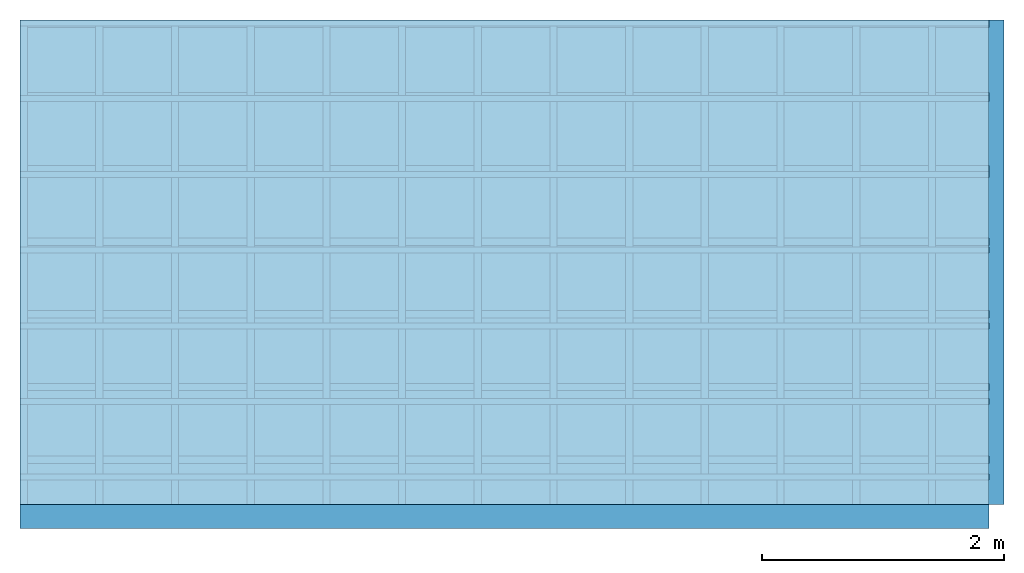
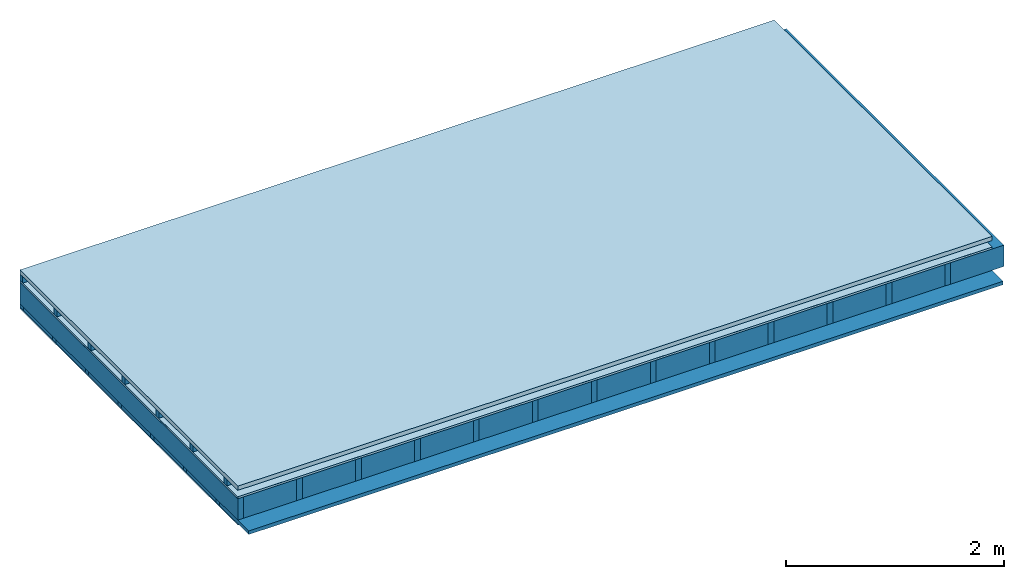
# One storey: 5 members, 4 plates, 1 element without a shape of its own.
"""IFC4 building model written with IfcOpenShell, lengths in metres."""

from ifc_helpers import new_model, si_unit, derived_unit, direction, frame, frame_2d, origin, origin_with_axes, place, context, project, spatial, rectangle, extrude, material, layer, layer_set, type_object, element, aggregate, save


model = new_model("IFC4")

# Units and contexts
plan_context = context("Plan", 3, precision=1e-05, world=origin(), true_north=direction((0.0, 1.0)))
model_context = context("Model", 3, precision=1e-05, world=origin(), true_north=direction((0.0, 1.0)))
ifc_project = project(units=[si_unit("LENGTHUNIT", "METRE"), derived_unit("SOUNDPRESSUREUNIT", [(si_unit("PRESSUREUNIT", "PASCAL", prefix="MICRO"), 0)]), si_unit("ENERGYUNIT", "JOULE", prefix="MEGA"), si_unit("MASSUNIT", "GRAM", prefix="KILO"), derived_unit("THERMALTRANSMITTANCEUNIT", [(si_unit("POWERUNIT", "WATT"), 1), (si_unit("AREAUNIT", "SQUARE_METRE"), -1), (si_unit("THERMODYNAMICTEMPERATUREUNIT", "KELVIN"), -1)]), derived_unit("AREADENSITYUNIT", [(si_unit("MASSUNIT", "GRAM", prefix="KILO"), 1), (si_unit("AREAUNIT", "SQUARE_METRE"), -1)]), derived_unit("USERDEFINED", [(si_unit("ENERGYUNIT", "JOULE", prefix="MEGA"), 1), (si_unit("AREAUNIT", "SQUARE_METRE"), -1)])], contexts=[plan_context, model_context])

# Site, building, storey
site = spatial("IfcSite", under=ifc_project)
building_placement = place(None, origin())
building = spatial("IfcBuilding", under=site, at=building_placement)
storey_placement = place(building_placement, origin())
storey = spatial("IfcBuildingStorey", under=building, at=storey_placement)

# Slab, members, plates
ifc_material_1 = material(Name="Roof tiles", Category="03.015")
ifc_layer_1 = layer(ifc_material_1, 0.047, Name="Roofing")
ifc_layer_2 = layer(None, 0.072, Name="Battens / profiles")
ifc_material_2 = material(Name="Roofing underlay", Category="09.008")
ifc_layer_3 = layer(ifc_material_2, 0.00018, Name="Under the roof")
ifc_material_3 = material(Category="10.009")
ifc_layer_4 = layer(ifc_material_3, 0.022, Name="Exterior insulation layer 1")
ifc_material_4 = material(Name="no composite action")
ifc_layer_5 = layer(ifc_material_4, 0.0, Name="Bond")
ifc_layer_6 = layer(None, 0.24, Name="Supporting structure")
ifc_material_5 = material(Name="of the art")
ifc_layer_7 = layer(ifc_material_5, 0.0, Name="Bond")
ifc_layer_8 = layer(None, 0.04, Name="Battens / profiles")
ifc_material_6 = material(Name="Plasterboard type A", Category="03.008")
ifc_layer_9 = layer(ifc_material_6, 0.015, Name="Covering below 1st layer")
ifc_material_7 = material(Name="joints", Category="04.017")
ifc_layer_10 = layer(ifc_material_7, 0.0, Name="Surface below")
ifc_layer_set = layer_set([ifc_layer_1, ifc_layer_2, ifc_layer_3, ifc_layer_4, ifc_layer_5, ifc_layer_6, ifc_layer_7, ifc_layer_8, ifc_layer_9, ifc_layer_10])
slab_type = type_object("IfcSlabType", Name="E0090", PredefinedType="NOTDEFINED", material=ifc_layer_set)
slab_placement = place(None, frame((0.0, 0.0, 0.0), z_axis=(0.0, 0.0, -1.0), x_axis=(1.0, 0.0, 0.0)))
slab = element("IfcSlab", 1, at=slab_placement, inside=storey, type_object=slab_type, material=ifc_layer_set, Name="Slab #1")
ifc_material_8 = material()
member_1_placement = place(slab_placement, origin())
member_1 = element("IfcMember", 2, at=member_1_placement, material=ifc_material_8, Name="Battens / profiles", context=plan_context, shape_type="SweptSolid", body=[
    extrude(rectangle(XDim=0.05, YDim=0.072, at=frame_2d((0.025, 0.036), x_axis=(1.0, 0.0))), frame((0.0, 0.0, 0.047), z_axis=(1.0, 0.0, 0.0), x_axis=(0.0, 1.0, 0.0)), (0.0, 0.0, 1.0), 8.0),
    extrude(rectangle(XDim=0.05, YDim=0.072, at=frame_2d((0.025, 0.036), x_axis=(1.0, 0.0))), frame((0.0, 0.625, 0.047), z_axis=(1.0, 0.0, 0.0), x_axis=(0.0, 1.0, 0.0)), (0.0, 0.0, 1.0), 8.0),
    extrude(rectangle(XDim=0.05, YDim=0.072, at=frame_2d((0.025, 0.036), x_axis=(1.0, 0.0))), frame((0.0, 1.25, 0.047), z_axis=(1.0, 0.0, 0.0), x_axis=(0.0, 1.0, 0.0)), (0.0, 0.0, 1.0), 8.0),
    extrude(rectangle(XDim=0.05, YDim=0.072, at=frame_2d((0.025, 0.036), x_axis=(1.0, 0.0))), frame((0.0, 1.875, 0.047), z_axis=(1.0, 0.0, 0.0), x_axis=(0.0, 1.0, 0.0)), (0.0, 0.0, 1.0), 8.0),
    extrude(rectangle(XDim=0.05, YDim=0.072, at=frame_2d((0.025, 0.036), x_axis=(1.0, 0.0))), frame((0.0, 2.5, 0.047), z_axis=(1.0, 0.0, 0.0), x_axis=(0.0, 1.0, 0.0)), (0.0, 0.0, 1.0), 8.0),
    extrude(rectangle(XDim=0.05, YDim=0.072, at=frame_2d((0.025, 0.036), x_axis=(1.0, 0.0))), frame((0.0, 3.125, 0.047), z_axis=(1.0, 0.0, 0.0), x_axis=(0.0, 1.0, 0.0)), (0.0, 0.0, 1.0), 8.0),
    extrude(rectangle(XDim=0.05, YDim=0.072, at=frame_2d((0.025, 0.036), x_axis=(1.0, 0.0))), frame((0.0, 3.75, 0.047), z_axis=(1.0, 0.0, 0.0), x_axis=(0.0, 1.0, 0.0)), (0.0, 0.0, 1.0), 8.0),
])
ifc_material_9 = material()
member_2_placement = place(slab_placement, origin())
member_2 = element("IfcMember", 3, at=member_2_placement, material=ifc_material_9, Name="Supporting structure", context=plan_context, shape_type="SweptSolid", body=[
    extrude(rectangle(XDim=0.06, YDim=0.24, at=frame_2d((0.03, 0.12), x_axis=(1.0, 0.0))), frame((0.0, 4.0, 0.14118), z_axis=(0.0, -1.0, 0.0), x_axis=(1.0, 0.0, 0.0)), (0.0, 0.0, 1.0), 4.0),
    extrude(rectangle(XDim=0.06, YDim=0.24, at=frame_2d((0.03, 0.12), x_axis=(1.0, 0.0))), frame((0.625, 4.0, 0.14118), z_axis=(0.0, -1.0, 0.0), x_axis=(1.0, 0.0, 0.0)), (0.0, 0.0, 1.0), 4.0),
    extrude(rectangle(XDim=0.06, YDim=0.24, at=frame_2d((0.03, 0.12), x_axis=(1.0, 0.0))), frame((1.25, 4.0, 0.14118), z_axis=(0.0, -1.0, 0.0), x_axis=(1.0, 0.0, 0.0)), (0.0, 0.0, 1.0), 4.0),
    extrude(rectangle(XDim=0.06, YDim=0.24, at=frame_2d((0.03, 0.12), x_axis=(1.0, 0.0))), frame((1.875, 4.0, 0.14118), z_axis=(0.0, -1.0, 0.0), x_axis=(1.0, 0.0, 0.0)), (0.0, 0.0, 1.0), 4.0),
    extrude(rectangle(XDim=0.06, YDim=0.24, at=frame_2d((0.03, 0.12), x_axis=(1.0, 0.0))), frame((2.5, 4.0, 0.14118), z_axis=(0.0, -1.0, 0.0), x_axis=(1.0, 0.0, 0.0)), (0.0, 0.0, 1.0), 4.0),
    extrude(rectangle(XDim=0.06, YDim=0.24, at=frame_2d((0.03, 0.12), x_axis=(1.0, 0.0))), frame((3.125, 4.0, 0.14118), z_axis=(0.0, -1.0, 0.0), x_axis=(1.0, 0.0, 0.0)), (0.0, 0.0, 1.0), 4.0),
    extrude(rectangle(XDim=0.06, YDim=0.24, at=frame_2d((0.03, 0.12), x_axis=(1.0, 0.0))), frame((3.75, 4.0, 0.14118), z_axis=(0.0, -1.0, 0.0), x_axis=(1.0, 0.0, 0.0)), (0.0, 0.0, 1.0), 4.0),
    extrude(rectangle(XDim=0.06, YDim=0.24, at=frame_2d((0.03, 0.12), x_axis=(1.0, 0.0))), frame((4.375, 4.0, 0.14118), z_axis=(0.0, -1.0, 0.0), x_axis=(1.0, 0.0, 0.0)), (0.0, 0.0, 1.0), 4.0),
    extrude(rectangle(XDim=0.06, YDim=0.24, at=frame_2d((0.03, 0.12), x_axis=(1.0, 0.0))), frame((5.0, 4.0, 0.14118), z_axis=(0.0, -1.0, 0.0), x_axis=(1.0, 0.0, 0.0)), (0.0, 0.0, 1.0), 4.0),
    extrude(rectangle(XDim=0.06, YDim=0.24, at=frame_2d((0.03, 0.12), x_axis=(1.0, 0.0))), frame((5.625, 4.0, 0.14118), z_axis=(0.0, -1.0, 0.0), x_axis=(1.0, 0.0, 0.0)), (0.0, 0.0, 1.0), 4.0),
    extrude(rectangle(XDim=0.06, YDim=0.24, at=frame_2d((0.03, 0.12), x_axis=(1.0, 0.0))), frame((6.25, 4.0, 0.14118), z_axis=(0.0, -1.0, 0.0), x_axis=(1.0, 0.0, 0.0)), (0.0, 0.0, 1.0), 4.0),
    extrude(rectangle(XDim=0.06, YDim=0.24, at=frame_2d((0.03, 0.12), x_axis=(1.0, 0.0))), frame((6.875, 4.0, 0.14118), z_axis=(0.0, -1.0, 0.0), x_axis=(1.0, 0.0, 0.0)), (0.0, 0.0, 1.0), 4.0),
    extrude(rectangle(XDim=0.06, YDim=0.24, at=frame_2d((0.03, 0.12), x_axis=(1.0, 0.0))), frame((7.5, 4.0, 0.14118), z_axis=(0.0, -1.0, 0.0), x_axis=(1.0, 0.0, 0.0)), (0.0, 0.0, 1.0), 4.0),
])
ifc_material_10 = material()
member_3_placement = place(slab_placement, origin())
member_3 = element("IfcMember", 4, at=member_3_placement, material=ifc_material_10, Name="Cavity", context=plan_context, shape_type="SweptSolid", body=[
    extrude(rectangle(XDim=0.565, YDim=0.24, at=frame_2d((0.2825, 0.12), x_axis=(1.0, 0.0))), frame((0.06, 4.0, 0.14118), z_axis=(0.0, -1.0, 0.0), x_axis=(1.0, 0.0, 0.0)), (0.0, 0.0, 1.0), 4.0),
    extrude(rectangle(XDim=0.565, YDim=0.24, at=frame_2d((0.2825, 0.12), x_axis=(1.0, 0.0))), frame((0.685, 4.0, 0.14118), z_axis=(0.0, -1.0, 0.0), x_axis=(1.0, 0.0, 0.0)), (0.0, 0.0, 1.0), 4.0),
    extrude(rectangle(XDim=0.565, YDim=0.24, at=frame_2d((0.2825, 0.12), x_axis=(1.0, 0.0))), frame((1.31, 4.0, 0.14118), z_axis=(0.0, -1.0, 0.0), x_axis=(1.0, 0.0, 0.0)), (0.0, 0.0, 1.0), 4.0),
    extrude(rectangle(XDim=0.565, YDim=0.24, at=frame_2d((0.2825, 0.12), x_axis=(1.0, 0.0))), frame((1.935, 4.0, 0.14118), z_axis=(0.0, -1.0, 0.0), x_axis=(1.0, 0.0, 0.0)), (0.0, 0.0, 1.0), 4.0),
    extrude(rectangle(XDim=0.565, YDim=0.24, at=frame_2d((0.2825, 0.12), x_axis=(1.0, 0.0))), frame((2.56, 4.0, 0.14118), z_axis=(0.0, -1.0, 0.0), x_axis=(1.0, 0.0, 0.0)), (0.0, 0.0, 1.0), 4.0),
    extrude(rectangle(XDim=0.565, YDim=0.24, at=frame_2d((0.2825, 0.12), x_axis=(1.0, 0.0))), frame((3.185, 4.0, 0.14118), z_axis=(0.0, -1.0, 0.0), x_axis=(1.0, 0.0, 0.0)), (0.0, 0.0, 1.0), 4.0),
    extrude(rectangle(XDim=0.565, YDim=0.24, at=frame_2d((0.2825, 0.12), x_axis=(1.0, 0.0))), frame((3.81, 4.0, 0.14118), z_axis=(0.0, -1.0, 0.0), x_axis=(1.0, 0.0, 0.0)), (0.0, 0.0, 1.0), 4.0),
    extrude(rectangle(XDim=0.565, YDim=0.24, at=frame_2d((0.2825, 0.12), x_axis=(1.0, 0.0))), frame((4.435, 4.0, 0.14118), z_axis=(0.0, -1.0, 0.0), x_axis=(1.0, 0.0, 0.0)), (0.0, 0.0, 1.0), 4.0),
    extrude(rectangle(XDim=0.565, YDim=0.24, at=frame_2d((0.2825, 0.12), x_axis=(1.0, 0.0))), frame((5.06, 4.0, 0.14118), z_axis=(0.0, -1.0, 0.0), x_axis=(1.0, 0.0, 0.0)), (0.0, 0.0, 1.0), 4.0),
    extrude(rectangle(XDim=0.565, YDim=0.24, at=frame_2d((0.2825, 0.12), x_axis=(1.0, 0.0))), frame((5.685, 4.0, 0.14118), z_axis=(0.0, -1.0, 0.0), x_axis=(1.0, 0.0, 0.0)), (0.0, 0.0, 1.0), 4.0),
    extrude(rectangle(XDim=0.565, YDim=0.24, at=frame_2d((0.2825, 0.12), x_axis=(1.0, 0.0))), frame((6.31, 4.0, 0.14118), z_axis=(0.0, -1.0, 0.0), x_axis=(1.0, 0.0, 0.0)), (0.0, 0.0, 1.0), 4.0),
    extrude(rectangle(XDim=0.565, YDim=0.24, at=frame_2d((0.2825, 0.12), x_axis=(1.0, 0.0))), frame((6.935, 4.0, 0.14118), z_axis=(0.0, -1.0, 0.0), x_axis=(1.0, 0.0, 0.0)), (0.0, 0.0, 1.0), 4.0),
    extrude(rectangle(XDim=0.565, YDim=0.24, at=frame_2d((0.2825, 0.12), x_axis=(1.0, 0.0))), frame((7.56, 4.0, 0.14118), z_axis=(0.0, -1.0, 0.0), x_axis=(1.0, 0.0, 0.0)), (0.0, 0.0, 1.0), 4.0),
])
ifc_material_11 = material()
member_4_placement = place(slab_placement, origin())
member_4 = element("IfcMember", 5, at=member_4_placement, material=ifc_material_11, Name="Battens / profiles", context=plan_context, shape_type="SweptSolid", body=[
    extrude(rectangle(XDim=0.06, YDim=0.04, at=frame_2d((0.03, 0.02), x_axis=(1.0, 0.0))), frame((0.0, 0.0, 0.38118), z_axis=(1.0, 0.0, 0.0), x_axis=(0.0, 1.0, 0.0)), (0.0, 0.0, 1.0), 8.0),
    extrude(rectangle(XDim=0.06, YDim=0.04, at=frame_2d((0.03, 0.02), x_axis=(1.0, 0.0))), frame((0.0, 0.6, 0.38118), z_axis=(1.0, 0.0, 0.0), x_axis=(0.0, 1.0, 0.0)), (0.0, 0.0, 1.0), 8.0),
    extrude(rectangle(XDim=0.06, YDim=0.04, at=frame_2d((0.03, 0.02), x_axis=(1.0, 0.0))), frame((0.0, 1.2, 0.38118), z_axis=(1.0, 0.0, 0.0), x_axis=(0.0, 1.0, 0.0)), (0.0, 0.0, 1.0), 8.0),
    extrude(rectangle(XDim=0.06, YDim=0.04, at=frame_2d((0.03, 0.02), x_axis=(1.0, 0.0))), frame((0.0, 1.8, 0.38118), z_axis=(1.0, 0.0, 0.0), x_axis=(0.0, 1.0, 0.0)), (0.0, 0.0, 1.0), 8.0),
    extrude(rectangle(XDim=0.06, YDim=0.04, at=frame_2d((0.03, 0.02), x_axis=(1.0, 0.0))), frame((0.0, 2.4, 0.38118), z_axis=(1.0, 0.0, 0.0), x_axis=(0.0, 1.0, 0.0)), (0.0, 0.0, 1.0), 8.0),
    extrude(rectangle(XDim=0.06, YDim=0.04, at=frame_2d((0.03, 0.02), x_axis=(1.0, 0.0))), frame((0.0, 3.0, 0.38118), z_axis=(1.0, 0.0, 0.0), x_axis=(0.0, 1.0, 0.0)), (0.0, 0.0, 1.0), 8.0),
    extrude(rectangle(XDim=0.06, YDim=0.04, at=frame_2d((0.03, 0.02), x_axis=(1.0, 0.0))), frame((0.0, 3.6, 0.38118), z_axis=(1.0, 0.0, 0.0), x_axis=(0.0, 1.0, 0.0)), (0.0, 0.0, 1.0), 8.0),
])
ifc_material_12 = material(Name="Mineral wool")
member_5_placement = place(slab_placement, origin())
member_5 = element("IfcMember", 6, at=member_5_placement, material=ifc_material_12, Name="Cavity", context=plan_context, shape_type="SweptSolid", body=[
    extrude(rectangle(XDim=0.54, YDim=0.04, at=frame_2d((0.27, 0.02), x_axis=(1.0, 0.0))), frame((0.0, 0.06, 0.38118), z_axis=(1.0, 0.0, 0.0), x_axis=(0.0, 1.0, 0.0)), (0.0, 0.0, 1.0), 8.0),
    extrude(rectangle(XDim=0.54, YDim=0.04, at=frame_2d((0.27, 0.02), x_axis=(1.0, 0.0))), frame((0.0, 0.66, 0.38118), z_axis=(1.0, 0.0, 0.0), x_axis=(0.0, 1.0, 0.0)), (0.0, 0.0, 1.0), 8.0),
    extrude(rectangle(XDim=0.54, YDim=0.04, at=frame_2d((0.27, 0.02), x_axis=(1.0, 0.0))), frame((0.0, 1.26, 0.38118), z_axis=(1.0, 0.0, 0.0), x_axis=(0.0, 1.0, 0.0)), (0.0, 0.0, 1.0), 8.0),
    extrude(rectangle(XDim=0.54, YDim=0.04, at=frame_2d((0.27, 0.02), x_axis=(1.0, 0.0))), frame((0.0, 1.86, 0.38118), z_axis=(1.0, 0.0, 0.0), x_axis=(0.0, 1.0, 0.0)), (0.0, 0.0, 1.0), 8.0),
    extrude(rectangle(XDim=0.54, YDim=0.04, at=frame_2d((0.27, 0.02), x_axis=(1.0, 0.0))), frame((0.0, 2.46, 0.38118), z_axis=(1.0, 0.0, 0.0), x_axis=(0.0, 1.0, 0.0)), (0.0, 0.0, 1.0), 8.0),
    extrude(rectangle(XDim=0.54, YDim=0.04, at=frame_2d((0.27, 0.02), x_axis=(1.0, 0.0))), frame((0.0, 3.06, 0.38118), z_axis=(1.0, 0.0, 0.0), x_axis=(0.0, 1.0, 0.0)), (0.0, 0.0, 1.0), 8.0),
    extrude(rectangle(XDim=0.54, YDim=0.04, at=frame_2d((0.27, 0.02), x_axis=(1.0, 0.0))), frame((0.0, 3.66, 0.38118), z_axis=(1.0, 0.0, 0.0), x_axis=(0.0, 1.0, 0.0)), (0.0, 0.0, 1.0), 8.0),
])
plate_1_placement = place(slab_placement, origin())
plate_1 = element("IfcPlate", 7, at=plate_1_placement, material=ifc_material_1, Name="Roofing", context=plan_context, shape_type="SweptSolid", body=[
    extrude(rectangle(XDim=8.0, YDim=4.0, at=frame_2d((4.0, 2.0), x_axis=(1.0, 0.0))), origin_with_axes(), (0.0, 0.0, 1.0), 0.047),
])
plate_2_placement = place(slab_placement, origin())
plate_2 = element("IfcPlate", 8, at=plate_2_placement, material=ifc_material_2, Name="Under the roof", context=plan_context, shape_type="SweptSolid", body=[
    extrude(rectangle(XDim=8.0, YDim=4.0, at=frame_2d((4.0, 2.0), x_axis=(1.0, 0.0))), frame((0.0, 0.0, 0.119), z_axis=(0.0, 0.0, 1.0), x_axis=(1.0, 0.0, 0.0)), (0.0, 0.0, 1.0), 0.00018),
])
plate_3_placement = place(slab_placement, origin())
plate_3 = element("IfcPlate", 9, at=plate_3_placement, material=ifc_material_3, Name="Exterior insulation layer 1", context=plan_context, shape_type="SweptSolid", body=[
    extrude(rectangle(XDim=8.0, YDim=4.0, at=frame_2d((4.0, 2.0), x_axis=(1.0, 0.0))), frame((0.0, 0.0, 0.11918), z_axis=(0.0, 0.0, 1.0), x_axis=(1.0, 0.0, 0.0)), (0.0, 0.0, 1.0), 0.022),
])
plate_4_placement = place(slab_placement, origin())
plate_4 = element("IfcPlate", 10, at=plate_4_placement, material=ifc_material_6, Name="Covering below 1st layer", context=plan_context, shape_type="SweptSolid", body=[
    extrude(rectangle(XDim=8.0, YDim=4.0, at=frame_2d((4.0, 2.0), x_axis=(1.0, 0.0))), frame((0.0, 0.0, 0.42118), z_axis=(0.0, 0.0, 1.0), x_axis=(1.0, 0.0, 0.0)), (0.0, 0.0, 1.0), 0.015),
])
aggregate(slab, [plate_1, member_1, plate_2, plate_3, member_2, member_3, member_4, member_5, plate_4])

save(model, "model.ifc")
